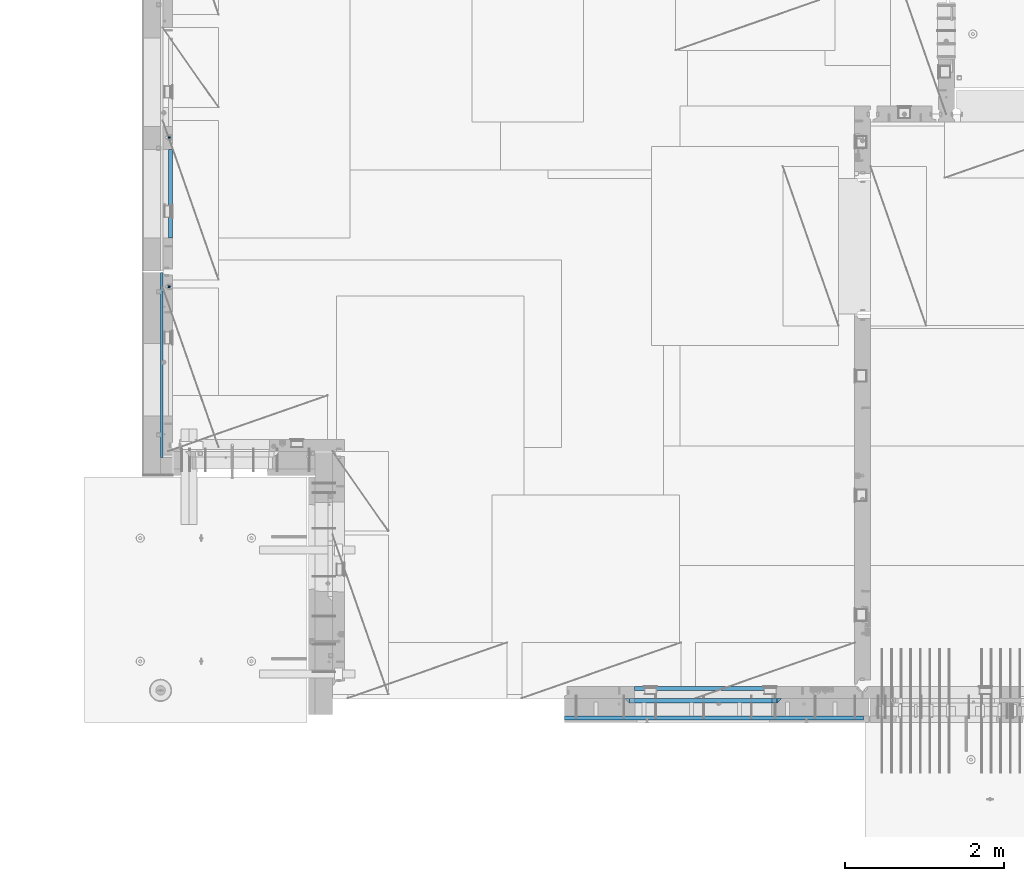
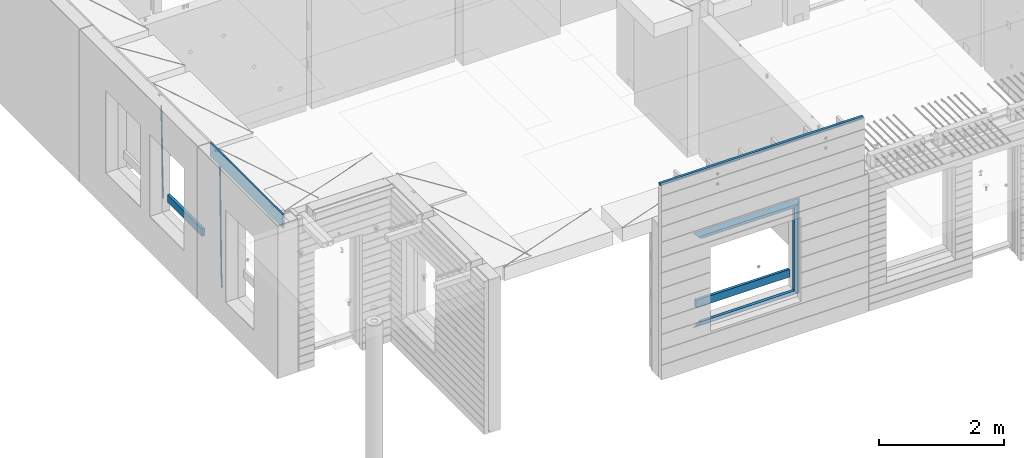
# One storey, part 76 of 309: 12 beams, 3 elements without a shape of their own.
"""IFC2X3 building model written with IfcOpenShell, lengths in millimetres."""

from ifc_helpers import new_model, si_unit, frame, origin_with_axes, place, context, subcontext, project, spatial, faceted_brep, material, type_object, element, aggregate, save


model = new_model("IFC2X3")

# Units and contexts
model_context = context("Model", 3, precision=1e-05, world=origin_with_axes())
body_context = subcontext(model_context, "Body", "Model", "MODEL_VIEW")
ifc_project = project(units=[si_unit("LENGTHUNIT", "METRE", prefix="MILLI"), si_unit("AREAUNIT", "SQUARE_METRE"), si_unit("VOLUMEUNIT", "CUBIC_METRE"), si_unit("MASSUNIT", "GRAM", prefix="KILO"), si_unit("TIMEUNIT", "SECOND"), si_unit("PLANEANGLEUNIT", "RADIAN"), si_unit("SOLIDANGLEUNIT", "STERADIAN"), si_unit("THERMODYNAMICTEMPERATUREUNIT", "DEGREE_CELSIUS"), si_unit("LUMINOUSINTENSITYUNIT", "LUMEN")], contexts=[model_context])

# Site, building, storey
site_placement = place(None, origin_with_axes())
site = spatial("IfcSite", under=ifc_project, at=site_placement, CompositionType="ELEMENT")
building_placement = place(site_placement, origin_with_axes())
building = spatial("IfcBuilding", under=site, at=building_placement, CompositionType="ELEMENT")
storey_placement = place(building_placement, origin_with_axes())
storey = spatial("IfcBuildingStorey", under=building, at=storey_placement, Name="7", CompositionType="ELEMENT", Elevation=0.0)

# Assembly, beam
assembly_1_placement = place(storey_placement, origin_with_axes())
assembly_1 = element("IfcElementAssembly", 1, at=assembly_1_placement, inside=storey, AssemblyPlace="NOTDEFINED", PredefinedType="REINFORCEMENT_UNIT")
ifc_material_1 = material()
beam_type_1 = type_object("IfcBeamType", Name="D20", PredefinedType="NOTDEFINED")
beam_1_placement = place(assembly_1_placement, frame((7964.99984877319, 14888.5021362169, 100590.0), z_axis=(-0.999642804636942, -0.000205726999925762, -0.0267249099902983), x_axis=(-0.0267249099948371, 4.30000201934385e-08, 0.999642825806181)))
beam_1 = element("IfcBeam", 2, at=beam_1_placement, type_object=beam_type_1, material=ifc_material_1, Name="JM20", ObjectType="D20", context=body_context, shape_type="Brep", body=[
    faceted_brep([(0.0, -10.0, 0.0), (-4.19531716033816e-08, -7.07106781186667, -7.07106781187031), (60.4266690400545, -7.0710677960451, -7.07106780570757), (60.4266690441291, -9.99999998418934, 6.15546014159918e-09), (0.0, 0.0, -10.0), (60.426669036824, 1.58106558956206e-08, -9.99999999384454), (4.196772351861e-08, 7.07106781186303, -7.07106781186667), (60.4266690363438, 7.07106782768096, -7.07106780570757), (0.0, 10.0, 0.0), (60.4266690388904, 10.0000000158179, 6.15182216279209e-09), (4.196772351861e-08, 7.07106781185939, 7.07106781185939), (60.4266690429649, 7.07106782768096, 7.07106781802577), (0.0, 0.0, 10.0), (60.4266690461809, 1.58179318532348e-08, 10.0000000061555), (-4.19531716033816e-08, -7.07106781187031, 7.07106781185939), (60.4266690466611, -7.07106779605238, 7.07106781802213), (61.0378400410118, -7.07106779588503, -7.07106780564936), (60.991799419251, -9.99999998403655, 6.21366780251265e-09), (61.0569027789461, 1.5985278878361e-08, -9.99999999378269), (61.0378209396877, 7.07106782784831, -7.07106780564936), (60.9917724058905, 10.0000000159635, 6.21366780251265e-09), (60.9457317841297, 7.07106782781193, 7.0710678180767), (60.9266690461809, 1.59488990902901e-08, 10.0000000062028), (60.9457508854539, -7.07106779591413, 7.0710678180767), (61.6489592143771, -7.07106614513759, -7.06310863441468), (61.5568818710308, -9.9999984576425, 0.00735959856683621), (61.6870830769039, 1.71821739058942e-06, -9.99179257185824), (61.6489210170112, 7.07106947854481, -7.06310888312146), (61.556827851804, 10.0000015422847, 0.00735924683976918), (61.4647505084577, 7.07106922979438, 7.07782747982128), (61.4266266459163, 1.36643211590126e-06, 10.0065114172685), (61.464788705809, -7.07106639389531, 7.07782772852806), (176.543135720174, -7.07075579406956, -5.56673531796696), (176.451058376813, -9.99968810657447, 1.50373291501455), (176.581259582701, 0.000312069292704109, -8.49541925541052), (176.543097522794, 7.07137982961285, -5.56673556667374), (176.451004357587, 10.00031189336, 1.50373256329476), (176.35892701424, 7.07137958085514, 8.57420079627263), (176.320803151699, 0.000311717507429421, 11.5028847337162), (176.358965211621, -7.07075604281999, 8.57420104497578), (177.098753836006, -7.07075429323595, -5.55949898843028), (176.98362511232, -9.99968666800123, 1.510669025065), (177.146421932586, 0.000313595905026887, -8.48805862247536), (177.098706077581, 7.07138133041735, -5.55949936166144), (176.983557571715, 10.0003133318824, 1.51066849724157), (176.868428848029, 7.07138095712435, 8.58083651073321), (176.820760751449, 0.000313067976094317, 11.5093961447819), (176.868476606425, -7.07075466652896, 8.58083688396073), (177.654312950661, -7.07075204110879, -5.54863964998367), (177.516135294456, -9.99968450931192, 1.52107783331303), (177.711524267797, 0.000315886711177882, -8.47701274570863), (177.654255632195, 7.07138358250813, -5.54864021007961), (177.516054233929, 10.0003154905207, 1.5210770412159), (177.377876577739, 7.0713830223176, 8.59079452451624), (177.320665260588, 0.000315094497636892, 11.5191676202448), (177.377933896176, -7.07075260129932, 8.59079508461218), (299.461778333818, -7.07025827596954, -3.16770791544877), (299.323600677439, -9.99919074416357, 3.90200956798253), (299.518989651391, 0.000809651852250681, -6.09608101123195), (299.46172101624, 7.07187734764193, -3.16770847554471), (299.323519618119, 10.0008092556727, 3.90200877589086), (299.18534196174, 7.07187678747687, 10.971726259324), (299.128130644167, 0.000808859655080596, 13.9000993551072), (299.185399279333, -7.07025883613824, 10.9717268194163), (300.005099199436, -7.07025607348805, -3.15708779472698), (299.971788958996, -9.99918809853989, 3.91467979818117), (300.018894160545, 0.00081167833377549, -6.08630953626562), (300.005085253739, 7.07187955030167, -3.15708750704471), (299.971753863239, 10.0008119014747, 3.91467990454839), (299.93844362146, 7.0718798403559, 10.9864468987271), (299.924648660366, 0.000812088532256894, 13.9156686402657), (299.938457567187, -7.07025578343564, 10.9864466110448), (300.548496018673, -7.07025720445017, -3.16258750978159), (300.620052478174, -9.9991894658433, 3.90811820064846), (300.518868553889, 0.000810637746326393, -6.09136977328126), (300.548525450897, 7.07187841925042, -3.16258766112878), (300.620094101629, 10.000810534113, 3.90811798661343), (300.69165056113, 7.07187827271991, 10.9788236970453), (300.721278025885, 0.000810430521596572, 13.907605960545), (300.691621128892, -7.07025735098068, 10.9788238483907), (1693.63216510082, -7.07315660432141, -17.2619766794614), (1693.70372156033, -10.0020888657109, -10.1912709690314), (1693.60253763606, -0.00208876212127507, -20.1907589429611), (1693.63219453306, 7.068979019381, -17.2619768308086), (1693.7037631838, 9.9979111342418, -10.1912711830664), (1693.77531964328, 7.06897887284867, -3.12056547263455), (1693.80494710806, -0.00208896934782388, -0.191783209134883), (1693.77529021105, -7.0731567508501, -3.12056532128736), (1694.29779868275, -7.07315798969103, -17.2687135518572), (1694.26743251897, -10.0020900389554, -10.1969762833342), (1694.34857500881, -0.00209031483609579, -20.1983095815103), (1694.39001741401, 7.06897744213711, -17.2696467503938), (1694.39784949942, 9.99790968965317, -10.1982960253627), (1694.36748333565, 7.06897764038877, -3.12655875683777), (1694.3167070096, -0.00209003446616407, -0.196962727188293), (1694.2752646044, -7.07315779143937, -3.125625558303), (1694.96335083364, -7.08183692566672, -17.2598557114488), (1694.83107451542, -10.0094400457037, -10.1894747662172), (1695.09452111425, -0.0118176043979474, -20.1883817771341), (1695.14774758583, 7.05909648594388, -17.259562111758), (1695.09185090323, 9.98885976961174, -10.1890595535533), (1694.95957458501, 7.0612566495729, -3.11867860832172), (1694.82840430441, -0.00876267169223865, -0.190152542638316), (1694.77517783281, -7.07967676203589, -3.11897220801256), (1716.74088258609, -7.36582038739652, -16.9700183177756), (1716.60860626785, -10.2934235074299, -9.8996373725422), (1716.87205286669, -0.295801066125932, -19.898544383459), (1716.92527933829, 6.77511302421226, -16.9697247180848), (1716.86938265568, 9.70487630788193, -9.89922215988008), (1716.73710633747, 6.77727318784673, -2.82884121464849), (1716.60593605686, -0.292746133423861, 0.0996848510367272), (1716.55270958526, -7.36366022376751, -2.82913481433934), (1717.37632925155, -7.37410674169405, -16.9615611515819), (1717.2686961548, -10.302031214369, -9.89085222946233), (1717.45037731848, -0.30334253509136, -19.8908474573927), (1717.44746400231, 6.76830362954752, -16.96277495703), (1717.36929588411, 9.6983573372836, -9.89256880959147), (1717.26166278738, 6.77043286460685, -2.82185988747187), (1717.18761472043, -0.300331341994024, 0.107426418340765), (1717.1905280366, -7.3719775066329, -2.82064608202199), (1718.0118297398, -7.37223067542982, -16.9532990407679), (1717.92884180055, -10.3000626540106, -9.8822625771154), (1718.02875100763, -0.301644694996867, -19.8833453418993), (1717.96969335481, 6.76984191386691, -16.9560200956876), (1717.86925195342, 9.69984820183527, -9.88611072988533), (1717.78626401415, 6.77201622325447, -2.81507426623284), (1717.76934274634, -0.298569757178484, 0.114972034898528), (1717.82840039914, -7.37005636604226, -2.81235321131317), (1818.03261514839, -7.07396855575644, -15.6559248891263), (1817.94962720915, -10.0018005343409, -8.58488842547376), (1818.04953641623, -0.00338257532712305, -18.5859711902594), (1817.99047876342, 7.06810403353848, -15.6586459440477), (1817.89003736203, 9.99811032150683, -8.58873657824552), (1817.80704942276, 7.07027834292421, -1.51770011459121), (1817.79012815493, -0.00030763750692131, 1.41234618654016), (1817.84918580775, -7.07179424637252, -1.51497905967153)], [[[0, 1, 2, 3]], [[1, 4, 5, 2]], [[4, 6, 7, 5]], [[6, 8, 9, 7]], [[8, 10, 11, 9]], [[10, 12, 13, 11]], [[12, 14, 15, 13]], [[14, 0, 3, 15]], [[14, 12, 10, 8, 6, 4, 1, 0]], [[3, 2, 16, 17]], [[2, 5, 18, 16]], [[5, 7, 19, 18]], [[7, 9, 20, 19]], [[9, 11, 21, 20]], [[11, 13, 22, 21]], [[13, 15, 23, 22]], [[15, 3, 17, 23]], [[17, 16, 24, 25]], [[16, 18, 26, 24]], [[18, 19, 27, 26]], [[19, 20, 28, 27]], [[20, 21, 29, 28]], [[21, 22, 30, 29]], [[22, 23, 31, 30]], [[23, 17, 25, 31]], [[25, 24, 32, 33]], [[24, 26, 34, 32]], [[26, 27, 35, 34]], [[27, 28, 36, 35]], [[28, 29, 37, 36]], [[29, 30, 38, 37]], [[30, 31, 39, 38]], [[31, 25, 33, 39]], [[33, 32, 40, 41]], [[32, 34, 42, 40]], [[34, 35, 43, 42]], [[35, 36, 44, 43]], [[36, 37, 45, 44]], [[37, 38, 46, 45]], [[38, 39, 47, 46]], [[39, 33, 41, 47]], [[41, 40, 48, 49]], [[40, 42, 50, 48]], [[42, 43, 51, 50]], [[43, 44, 52, 51]], [[44, 45, 53, 52]], [[45, 46, 54, 53]], [[46, 47, 55, 54]], [[47, 41, 49, 55]], [[49, 48, 56, 57]], [[48, 50, 58, 56]], [[50, 51, 59, 58]], [[51, 52, 60, 59]], [[52, 53, 61, 60]], [[53, 54, 62, 61]], [[54, 55, 63, 62]], [[55, 49, 57, 63]], [[57, 56, 64, 65]], [[56, 58, 66, 64]], [[58, 59, 67, 66]], [[59, 60, 68, 67]], [[60, 61, 69, 68]], [[61, 62, 70, 69]], [[62, 63, 71, 70]], [[63, 57, 65, 71]], [[65, 64, 72, 73]], [[64, 66, 74, 72]], [[66, 67, 75, 74]], [[67, 68, 76, 75]], [[68, 69, 77, 76]], [[69, 70, 78, 77]], [[70, 71, 79, 78]], [[71, 65, 73, 79]], [[73, 72, 80, 81]], [[72, 74, 82, 80]], [[74, 75, 83, 82]], [[75, 76, 84, 83]], [[76, 77, 85, 84]], [[77, 78, 86, 85]], [[78, 79, 87, 86]], [[79, 73, 81, 87]], [[81, 80, 88, 89]], [[80, 82, 90, 88]], [[82, 83, 91, 90]], [[83, 84, 92, 91]], [[84, 85, 93, 92]], [[85, 86, 94, 93]], [[86, 87, 95, 94]], [[87, 81, 89, 95]], [[89, 88, 96, 97]], [[88, 90, 98, 96]], [[90, 91, 99, 98]], [[91, 92, 100, 99]], [[92, 93, 101, 100]], [[93, 94, 102, 101]], [[94, 95, 103, 102]], [[95, 89, 97, 103]], [[97, 96, 104, 105]], [[96, 98, 106, 104]], [[98, 99, 107, 106]], [[99, 100, 108, 107]], [[100, 101, 109, 108]], [[101, 102, 110, 109]], [[102, 103, 111, 110]], [[103, 97, 105, 111]], [[105, 104, 112, 113]], [[104, 106, 114, 112]], [[106, 107, 115, 114]], [[107, 108, 116, 115]], [[108, 109, 117, 116]], [[109, 110, 118, 117]], [[110, 111, 119, 118]], [[111, 105, 113, 119]], [[113, 112, 120, 121]], [[112, 114, 122, 120]], [[114, 115, 123, 122]], [[115, 116, 124, 123]], [[116, 117, 125, 124]], [[117, 118, 126, 125]], [[118, 119, 127, 126]], [[119, 113, 121, 127]], [[121, 120, 128, 129]], [[120, 122, 130, 128]], [[122, 123, 131, 130]], [[123, 124, 132, 131]], [[124, 125, 133, 132]], [[125, 126, 134, 133]], [[126, 127, 135, 134]], [[127, 121, 129, 135]], [[130, 131, 132, 133, 134, 135, 129, 128]]]),
])

assembly_2_placement = place(storey_placement, origin_with_axes())
assembly_2 = element("IfcElementAssembly", 3, at=assembly_2_placement, inside=storey, AssemblyPlace="NOTDEFINED", PredefinedType="REINFORCEMENT_UNIT")
beam_2_placement = place(assembly_2_placement, frame((7964.99972837123, 13015.0021274634, 99990.0), z_axis=(-0.999642804636942, -0.000205726999925762, -0.0267249099902983), x_axis=(-0.0267249099948371, 4.30000201934385e-08, 0.999642825806181)))
beam_2 = element("IfcBeam", 4, at=beam_2_placement, type_object=beam_type_1, material=ifc_material_1, Name="JM20", ObjectType="D20", context=body_context, shape_type="Brep", body=[
    faceted_brep([(0.0, -10.0, 0.0), (-4.19531716033816e-08, -7.07106781186667, -7.07106781187031), (60.4266690400545, -7.0710677960451, -7.07106780570757), (60.4266690441291, -9.99999998418934, 6.15546014159918e-09), (0.0, 0.0, -10.0), (60.426669036824, 1.58106558956206e-08, -9.99999999384454), (4.196772351861e-08, 7.07106781186303, -7.07106781186667), (60.4266690363438, 7.07106782768096, -7.07106780570757), (0.0, 10.0, 0.0), (60.4266690388904, 10.0000000158179, 6.15182216279209e-09), (4.196772351861e-08, 7.07106781185939, 7.07106781185939), (60.4266690429649, 7.07106782768096, 7.07106781802577), (0.0, 0.0, 10.0), (60.4266690461809, 1.58179318532348e-08, 10.0000000061555), (-4.19531716033816e-08, -7.07106781187031, 7.07106781185939), (60.4266690466611, -7.07106779605238, 7.07106781802213), (61.0378400410118, -7.07106779588503, -7.07106780564936), (60.991799419251, -9.99999998403655, 6.21366780251265e-09), (61.0569027789461, 1.5985278878361e-08, -9.99999999378269), (61.0378209396877, 7.07106782784831, -7.07106780564936), (60.9917724058905, 10.0000000159635, 6.21366780251265e-09), (60.9457317841297, 7.07106782781193, 7.0710678180767), (60.9266690461809, 1.59488990902901e-08, 10.0000000062028), (60.9457508854539, -7.07106779591413, 7.0710678180767), (61.6489592143771, -7.07106614513759, -7.06310863441468), (61.5568818710308, -9.9999984576425, 0.00735959856683621), (61.6870830769039, 1.71821739058942e-06, -9.99179257185824), (61.6489210170112, 7.07106947854481, -7.06310888312146), (61.556827851804, 10.0000015422847, 0.00735924683976918), (61.4647505084577, 7.07106922979438, 7.07782747982128), (61.4266266459163, 1.36643211590126e-06, 10.0065114172685), (61.464788705809, -7.07106639389531, 7.07782772852806), (176.543135720174, -7.07075579406956, -5.56673531796696), (176.451058376813, -9.99968810657447, 1.50373291501455), (176.581259582701, 0.000312069292704109, -8.49541925541052), (176.543097522794, 7.07137982961285, -5.56673556667374), (176.451004357587, 10.00031189336, 1.50373256329476), (176.35892701424, 7.07137958085514, 8.57420079627263), (176.320803151699, 0.000311717507429421, 11.5028847337162), (176.358965211621, -7.07075604281999, 8.57420104497578), (177.098753836006, -7.07075429323595, -5.55949898843028), (176.98362511232, -9.99968666800123, 1.510669025065), (177.146421932586, 0.000313595905026887, -8.48805862247536), (177.098706077581, 7.07138133041735, -5.55949936166144), (176.983557571715, 10.0003133318824, 1.51066849724157), (176.868428848029, 7.07138095712435, 8.58083651073321), (176.820760751449, 0.000313067976094317, 11.5093961447819), (176.868476606425, -7.07075466652896, 8.58083688396073), (177.654312950661, -7.07075204110879, -5.54863964998367), (177.516135294456, -9.99968450931192, 1.52107783331303), (177.711524267797, 0.000315886711177882, -8.47701274570863), (177.654255632195, 7.07138358250813, -5.54864021007961), (177.516054233929, 10.0003154905207, 1.5210770412159), (177.377876577739, 7.0713830223176, 8.59079452451624), (177.320665260588, 0.000315094497636892, 11.5191676202448), (177.377933896176, -7.07075260129932, 8.59079508461218), (299.436796249574, -7.07025836271714, -3.1681962331204), (299.298618593355, -9.99919083092027, 3.90152125031091), (299.494007566798, 0.000809565110102994, -6.09656932889993), (299.436738931283, 7.07187726089978, -3.16819679320906), (299.298537533061, 10.0008091689197, 3.90152045822106), (299.160359876842, 7.07187670072017, 10.9712379416487), (299.103148559603, 0.000808772889286047, 13.8996110374392), (299.160417195119, -7.07025892290039, 10.9712385017483), (299.98743051647, -7.07025613056248, -3.15743315966392), (299.971788958996, -9.99918809853989, 3.91467979818117), (299.993912075952, 0.000811591617093654, -6.08679785393178), (299.987423933868, 7.07187949325817, -3.1574327280432), (299.971753863239, 10.0008119014747, 3.91467990454839), (299.95611230444, 7.07187992653053, 10.9867922621015), (299.949630744944, 0.000812204350950196, 13.9161569563694), (299.956118887014, -7.07025569729012, 10.9867918304735), (300.538107039494, -7.07025785017686, -3.16575821840888), (300.644985195438, -9.99919020432935, 3.90450175465594), (300.493854948218, 0.000810030429420294, -6.09435592770024), (300.538151196495, 7.071877773491, -3.16575855385963), (300.645047642858, 10.0008097955724, 3.90450128024895), (300.751925798773, 7.07187744142357, 10.9747612533101), (300.796177890064, 0.000809560813650023, 13.9033589625978), (300.751881641787, -7.07025818224065, 10.9747615887682), (2293.36490490142, -7.07648090940347, -33.2930642912361), (2293.47178305736, -10.0054132635523, -26.2228043181785), (2293.32065281013, -0.00541302880083094, -36.2216620005347), (2293.36494905842, 7.06565471425711, -33.2930646266868), (2293.47184550477, 9.99458673634581, -26.2228047925819), (2293.57872366071, 7.06565438219332, -19.1525448195243), (2293.62297575199, -0.00541349841296324, -16.2239471102366), (2293.57867950371, -7.0764812414709, -19.1525444840736), (2294.0658245362, -7.07648309818615, -33.3036607065333), (2294.05312277409, -10.0054150789219, -26.2315929392535), (2294.10928714235, -0.00541549149056664, -36.2335844756526), (2294.15805078732, 7.06565223761572, -33.3050546393533), (2294.18355038921, 9.99458451388637, -26.2335642579346), (2294.17084862708, 7.06565253314329, -19.1614964906439), (2294.12738602093, -0.00541507354500936, -16.2315727215355), (2294.07862237596, -7.07648280265857, -19.1601025578348), (2294.76670261032, -7.08562269121467, -33.294332712383), (2294.63442802057, -10.0129954178956, -26.2238563411993), (2294.89787471293, -0.0156988342423574, -36.2230891548279), (2294.95110548967, 7.05531064255774, -33.2944998654275), (2294.89521307347, 9.98530428734011, -26.2240927312887), (2294.76293848372, 7.0579315606592, -19.1536163601049), (2294.63176638114, -0.0119922963167483, -16.2248599176673), (2294.57853560438, -7.08300177311321, -19.1534492070678), (2316.52657204497, -7.36937582653991, -33.0047303660212), (2316.39429745522, -10.2967485532172, -25.9342539948302), (2316.65774414754, -0.299451969567599, -35.9334868084661), (2316.7109749243, 6.7715575072325, -33.0048975190657), (2316.65508250811, 9.70155115201487, -25.9344903849269), (2316.52280791836, 6.7741784253376, -18.8640140137468), (2316.39163581574, -0.295745431634714, -15.9352575713092), (2316.33840503903, -7.36675490843481, -18.863846860706), (2317.16202064224, -7.37766220584308, -32.9962731735213), (2317.05438744847, -10.3053562613532, -25.9254688497131), (2317.23607125619, -0.306993473008333, -35.925789846493), (2317.23316144495, 6.76474808850253, -32.9979477328052), (2317.15499573652, 9.6950321815566, -25.9278370341635), (2317.04736254275, 6.7673381260538, -18.8570327103698), (2316.97331192881, -0.303330606784584, -15.9275160373909), (2316.97622174003, -7.37507216829545, -18.8553581510787), (2317.79752306276, -7.37578610372293, -32.9880110666527), (2317.71453320107, -10.3033876998124, -25.9168792378296), (2317.81444760226, -0.305295583297266, -35.918287695793), (2317.75539265381, 6.76628640723357, -32.9911928173897), (2317.65495180529, 9.69652304524061, -25.9213789128698), (2317.5719619436, 6.76892144914746, -18.8502470840467), (2317.55503740412, -0.301569071270933, -15.9199704549137), (2317.61409235255, -7.3731510618054, -18.847065333317), (2417.8183084176, -7.07752398473531, -31.6906369377139), (2417.73531855589, -10.0051255808248, -24.6195051088798), (2417.83523295709, -0.007033464313281, -34.6209135668432), (2417.77617800863, 7.06454852621755, -31.6938186884508), (2417.67573716014, 9.99478516423187, -24.6240047839383), (2417.59274729842, 7.06718356813872, -17.5528729551006), (2417.57582275895, -0.00330695228694822, -14.6225963259749), (2417.6348777074, -7.07488894281778, -17.5496912043673)], [[[0, 1, 2, 3]], [[1, 4, 5, 2]], [[4, 6, 7, 5]], [[6, 8, 9, 7]], [[8, 10, 11, 9]], [[10, 12, 13, 11]], [[12, 14, 15, 13]], [[14, 0, 3, 15]], [[14, 12, 10, 8, 6, 4, 1, 0]], [[3, 2, 16, 17]], [[2, 5, 18, 16]], [[5, 7, 19, 18]], [[7, 9, 20, 19]], [[9, 11, 21, 20]], [[11, 13, 22, 21]], [[13, 15, 23, 22]], [[15, 3, 17, 23]], [[17, 16, 24, 25]], [[16, 18, 26, 24]], [[18, 19, 27, 26]], [[19, 20, 28, 27]], [[20, 21, 29, 28]], [[21, 22, 30, 29]], [[22, 23, 31, 30]], [[23, 17, 25, 31]], [[25, 24, 32, 33]], [[24, 26, 34, 32]], [[26, 27, 35, 34]], [[27, 28, 36, 35]], [[28, 29, 37, 36]], [[29, 30, 38, 37]], [[30, 31, 39, 38]], [[31, 25, 33, 39]], [[33, 32, 40, 41]], [[32, 34, 42, 40]], [[34, 35, 43, 42]], [[35, 36, 44, 43]], [[36, 37, 45, 44]], [[37, 38, 46, 45]], [[38, 39, 47, 46]], [[39, 33, 41, 47]], [[41, 40, 48, 49]], [[40, 42, 50, 48]], [[42, 43, 51, 50]], [[43, 44, 52, 51]], [[44, 45, 53, 52]], [[45, 46, 54, 53]], [[46, 47, 55, 54]], [[47, 41, 49, 55]], [[49, 48, 56, 57]], [[48, 50, 58, 56]], [[50, 51, 59, 58]], [[51, 52, 60, 59]], [[52, 53, 61, 60]], [[53, 54, 62, 61]], [[54, 55, 63, 62]], [[55, 49, 57, 63]], [[57, 56, 64, 65]], [[56, 58, 66, 64]], [[58, 59, 67, 66]], [[59, 60, 68, 67]], [[60, 61, 69, 68]], [[61, 62, 70, 69]], [[62, 63, 71, 70]], [[63, 57, 65, 71]], [[65, 64, 72, 73]], [[64, 66, 74, 72]], [[66, 67, 75, 74]], [[67, 68, 76, 75]], [[68, 69, 77, 76]], [[69, 70, 78, 77]], [[70, 71, 79, 78]], [[71, 65, 73, 79]], [[73, 72, 80, 81]], [[72, 74, 82, 80]], [[74, 75, 83, 82]], [[75, 76, 84, 83]], [[76, 77, 85, 84]], [[77, 78, 86, 85]], [[78, 79, 87, 86]], [[79, 73, 81, 87]], [[81, 80, 88, 89]], [[80, 82, 90, 88]], [[82, 83, 91, 90]], [[83, 84, 92, 91]], [[84, 85, 93, 92]], [[85, 86, 94, 93]], [[86, 87, 95, 94]], [[87, 81, 89, 95]], [[89, 88, 96, 97]], [[88, 90, 98, 96]], [[90, 91, 99, 98]], [[91, 92, 100, 99]], [[92, 93, 101, 100]], [[93, 94, 102, 101]], [[94, 95, 103, 102]], [[95, 89, 97, 103]], [[97, 96, 104, 105]], [[96, 98, 106, 104]], [[98, 99, 107, 106]], [[99, 100, 108, 107]], [[100, 101, 109, 108]], [[101, 102, 110, 109]], [[102, 103, 111, 110]], [[103, 97, 105, 111]], [[105, 104, 112, 113]], [[104, 106, 114, 112]], [[106, 107, 115, 114]], [[107, 108, 116, 115]], [[108, 109, 117, 116]], [[109, 110, 118, 117]], [[110, 111, 119, 118]], [[111, 105, 113, 119]], [[113, 112, 120, 121]], [[112, 114, 122, 120]], [[114, 115, 123, 122]], [[115, 116, 124, 123]], [[116, 117, 125, 124]], [[117, 118, 126, 125]], [[118, 119, 127, 126]], [[119, 113, 121, 127]], [[121, 120, 128, 129]], [[120, 122, 130, 128]], [[122, 123, 131, 130]], [[123, 124, 132, 131]], [[124, 125, 133, 132]], [[125, 126, 134, 133]], [[126, 127, 135, 134]], [[127, 121, 129, 135]], [[130, 131, 132, 133, 134, 135, 129, 128]]]),
])

# Assembly, beams
assembly_3_placement = place(storey_placement, origin_with_axes())
assembly_3 = element("IfcElementAssembly", 5, at=assembly_3_placement, inside=storey, AssemblyPlace="NOTDEFINED", PredefinedType="REINFORCEMENT_UNIT")
ifc_material_2 = material(Name="TIMBER/T24")
beam_type_2 = type_object("IfcBeamType", Name="PK50X50", PredefinedType="NOTDEFINED")
beam_3_placement = place(assembly_3_placement, frame((16670.0, 7605.0, 103545.0), z_axis=(0.0, 0.0, 1.0), x_axis=(-1.0, 3.00000001838171e-08, 0.0)))
beam_3 = element("IfcBeam", 6, at=beam_3_placement, type_object=beam_type_2, material=ifc_material_2, ObjectType="PK50X50", context=body_context, shape_type="Brep", body=[
    faceted_brep([(0.0, 25.0, 25.0), (0.0, -25.0, 25.0), (3750.0, -25.0, 25.0), (3750.0, 25.0, 25.0), (0.0, -25.0, -25.0), (3750.0, -25.0, -25.0), (0.0, 25.0, -25.0), (3750.0, 25.0, -25.0)], [[[0, 1, 2, 3]], [[1, 4, 5, 2]], [[4, 6, 7, 5]], [[6, 0, 3, 7]], [[5, 7, 3, 2]], [[4, 1, 0, 6]]]),
])
beam_type_3 = type_object("IfcBeamType", PredefinedType="NOTDEFINED")
beam_4_placement = place(assembly_3_placement, frame((13795.0009023501, 7974.99972412935, 100685.0), z_axis=(0.0, 0.0, 1.0), x_axis=(1.0, 0.0, 0.0)))
beam_4 = element("IfcBeam", 7, at=beam_4_placement, type_object=beam_type_3, material=ifc_material_2, context=body_context, shape_type="Brep", body=[
    faceted_brep([(-3.63797880709171e-12, 24.9999999999964, -75.0), (-3.63797880709171e-12, 24.9999999999964, 75.0), (1730.0, 25.0, 75.0), (1730.0, 25.0, -75.0), (0.0, -25.0000000000073, 75.0), (1730.0, -25.0, 75.0), (0.0, -25.0000000000073, -75.0), (1730.0, -25.0, -75.0)], [[[0, 1, 2, 3]], [[1, 4, 5, 2]], [[4, 6, 7, 5]], [[6, 0, 3, 7]], [[5, 7, 3, 2]], [[6, 4, 1, 0]]]),
])

# Beam
beam_5_placement = place(assembly_1_placement, frame((7975.00000026382, 14735.0004107749, 100685.0), z_axis=(0.0, 0.0, 1.0), x_axis=(0.0, -1.0, 0.0)))
beam_5 = element("IfcBeam", 8, at=beam_5_placement, type_object=beam_type_3, material=ifc_material_2, context=body_context, shape_type="Brep", body=[
    faceted_brep([(-3.63797880709171e-12, 24.9999999999964, -75.0), (-3.63797880709171e-12, 24.9999999999964, 75.0), (1110.0, 24.9999999999964, 75.0), (1110.0, 24.9999999999964, -75.0), (0.0, -25.0000000000073, 75.0), (1110.0, -25.0000000000073, 75.0), (0.0, -25.0000000000073, -75.0), (1110.0, -25.0000000000073, -75.0)], [[[0, 1, 2, 3]], [[1, 4, 5, 2]], [[4, 6, 7, 5]], [[6, 0, 3, 7]], [[5, 7, 3, 2]], [[6, 4, 1, 0]]]),
])

aggregate(assembly_1, [beam_1, beam_5])

ifc_material_3 = material(Name="CONCRETE/C25/30")
beam_type_4 = type_object("IfcBeamType", PredefinedType="NOTDEFINED")
beam_6_placement = place(assembly_3_placement, frame((13675.0004364773, 7820.0, 102145.0), z_axis=(0.0, 0.0, -1.0), x_axis=(1.0, 0.0, 0.0)))
beam_6 = element("IfcBeam", 9, at=beam_6_placement, type_object=beam_type_4, material=ifc_material_3, Name="SK", context=body_context, shape_type="Brep", body=[
    faceted_brep([(60.0000000000073, 30.0, 30.0), (0.0, -30.0, -30.0), (60.0000000000073, -30.0, 30.0), (1969.99980926514, -30.0, -30.0), (1909.99980926512, -30.0, 30.0), (1909.99980926512, 30.0, 30.0)], [[[0, 1, 2]], [[2, 1, 3, 4]], [[0, 2, 4, 5]], [[1, 0, 5, 3]], [[4, 3, 5]]]),
])

beam_7_placement = place(assembly_3_placement, frame((13735.0004364773, 7820.0, 102085.0), z_axis=(0.0, 0.0, -1.0), x_axis=(1.0, 0.0, 0.0)))
beam_7 = element("IfcBeam", 10, at=beam_7_placement, type_object=beam_type_4, material=ifc_material_3, Name="SK", context=body_context, shape_type="Brep", body=[
    faceted_brep([(1785.94575521108, -30.0, 24.0540540540533), (1784.32413358946, 30.0, 25.6756756756804), (65.6754849408117, 30.0, 25.6756756756804), (64.05386331919, -30.0, 24.0540540540533), (65.6754849408117, 30.0, 26.2932727940788), (64.05386331919, -30.0, 24.9033114044141), (0.0, -30.0, -30.0), (0.0, 30.0, -30.0), (1849.99980926514, -30.0, -30.0), (1785.94575521108, -30.0, 24.9034748914273), (1784.32413358946, 30.0, 26.293436281092), (1849.99980926514, 30.0, -30.0)], [[[0, 1, 2, 3]], [[3, 2, 4, 5]], [[6, 5, 4, 7]], [[0, 3, 5, 6, 8, 9]], [[1, 0, 9, 10]], [[7, 4, 2, 1, 10, 11]], [[6, 7, 11, 8]], [[10, 9, 8, 11]]]),
])

beam_8_placement = place(assembly_3_placement, frame((15615.0002457424, 7820.0, 102175.0), z_axis=(-1.0, 3.00000001838171e-08, 0.0), x_axis=(0.0, 0.0, -1.0)))
beam_8 = element("IfcBeam", 11, at=beam_8_placement, type_object=beam_type_4, material=ifc_material_3, Name="SK", context=body_context, shape_type="Brep", body=[
    faceted_brep([(60.0000000000073, 30.0, 30.0), (0.0, -30.0, -30.0), (60.0000000000073, -30.0, 30.0), (1855.0, -30.0, -30.0), (1795.00000000001, -30.0, 30.0), (1795.00000000001, 30.0, 30.0)], [[[0, 1, 2]], [[3, 4, 2, 1]], [[4, 5, 0, 2]], [[5, 3, 1, 0]], [[4, 3, 5]]]),
])

beam_9_placement = place(assembly_3_placement, frame((15645.0002457424, 7820.0, 100350.0), z_axis=(0.0, 0.0, 1.0), x_axis=(-1.0, 3.00000001838171e-08, 0.0)))
beam_9 = element("IfcBeam", 12, at=beam_9_placement, type_object=beam_type_4, material=ifc_material_3, Name="SK", context=body_context, shape_type="Brep", body=[
    faceted_brep([(1909.99980926512, -30.0, 30.0), (1969.99980926514, -30.0, -30.0), (1909.99980926512, 30.0, 30.0), (0.0, -30.0, -30.0), (60.0000000000073, 30.0, 30.0), (60.0000000000073, -30.0, 30.0)], [[[0, 1, 2]], [[3, 4, 2, 1]], [[4, 5, 0, 2]], [[5, 3, 1, 0]], [[4, 3, 5]]]),
])

beam_10_placement = place(assembly_3_placement, frame((15585.0002457424, 7820.0, 100410.0), z_axis=(0.0, 0.0, 1.0), x_axis=(-1.0, 3.00000001838171e-08, 0.0)))
beam_10 = element("IfcBeam", 13, at=beam_10_placement, type_object=beam_type_4, material=ifc_material_3, Name="SK", context=body_context, shape_type="Brep", body=[
    faceted_brep([(1785.94594594595, -30.0, 24.0540540540533), (1784.32432432433, 30.0, 25.6756756756804), (65.6756756756768, 30.0, 25.6756756756804), (64.0540540540533, -30.0, 24.0540540540533), (1785.94594594595, -30.0, 24.9033114043996), (1784.32432432433, 30.0, 26.2932727940788), (1849.99980926514, -30.0, -30.0), (1849.99980926514, 30.0, -30.0), (0.0, -30.0, -30.0), (0.0, 30.0, -30.0), (65.6756756756768, 30.0, 26.293436281092), (64.0540540540533, -30.0, 24.9034748914419)], [[[0, 1, 2, 3]], [[1, 0, 4, 5]], [[6, 7, 5, 4]], [[8, 9, 7, 6]], [[2, 1, 5, 7, 9, 10]], [[3, 2, 10, 11]], [[6, 4, 0, 3, 11, 8]], [[8, 11, 10, 9]]]),
])

beam_type_5 = type_object("IfcBeamType", PredefinedType="NOTDEFINED")
beam_11_placement = place(assembly_3_placement, frame((15550.0002457424, 7820.0, 102115.0), z_axis=(-1.0, 3.00000001838171e-08, 0.0), x_axis=(0.0, 0.0, -1.0)))
beam_11 = element("IfcBeam", 14, at=beam_11_placement, type_object=beam_type_5, material=ifc_material_3, Name="SK", context=body_context, shape_type="Brep", body=[
    faceted_brep([(0.0, -30.0, -35.0), (54.9034748914273, -30.0, 29.0540540540533), (56.2934362811066, 30.0, 30.6756756756768), (0.0, 30.0, -35.0), (1735.0, -30.0, -35.0), (1680.09652510857, -30.0, 29.0540540540533), (1678.70656371891, 30.0, 30.6756756756768), (1735.0, 30.0, -35.0)], [[[0, 1, 2, 3]], [[1, 0, 4, 5]], [[2, 1, 5, 6]], [[3, 2, 6, 7]], [[7, 4, 0, 3]], [[4, 7, 6, 5]]]),
])

aggregate(assembly_3, [beam_3, beam_6, beam_7, beam_8, beam_11, beam_9, beam_10, beam_4])

beam_type_6 = type_object("IfcBeamType", Name="270X30", PredefinedType="NOTDEFINED")
beam_12_placement = place(assembly_2_placement, frame((7864.99972556029, 13195.0003943318, 102605.0), z_axis=(0.0, 0.0, 1.0), x_axis=(0.0, -1.0, 0.0)))
beam_12 = element("IfcBeam", 15, at=beam_12_placement, type_object=beam_type_6, material=ifc_material_3, ObjectType="270X30", context=body_context, shape_type="Brep", body=[
    faceted_brep([(0.0, 15.0, -135.0), (0.0, 15.0, 135.0), (2320.00069431986, 15.0000000000009, 135.0), (2320.00069431986, 15.0000000000009, -135.0), (0.0, -15.0, 135.0), (2320.00069431986, -14.9999999999991, 135.0), (0.0, -15.0, -135.0), (2320.00069431986, -14.9999999999991, -135.0)], [[[0, 1, 2, 3]], [[1, 4, 5, 2]], [[4, 6, 7, 5]], [[6, 0, 3, 7]], [[5, 7, 3, 2]], [[6, 4, 1, 0]]]),
])

aggregate(assembly_2, [beam_2, beam_12])

save(model, "model.ifc")
